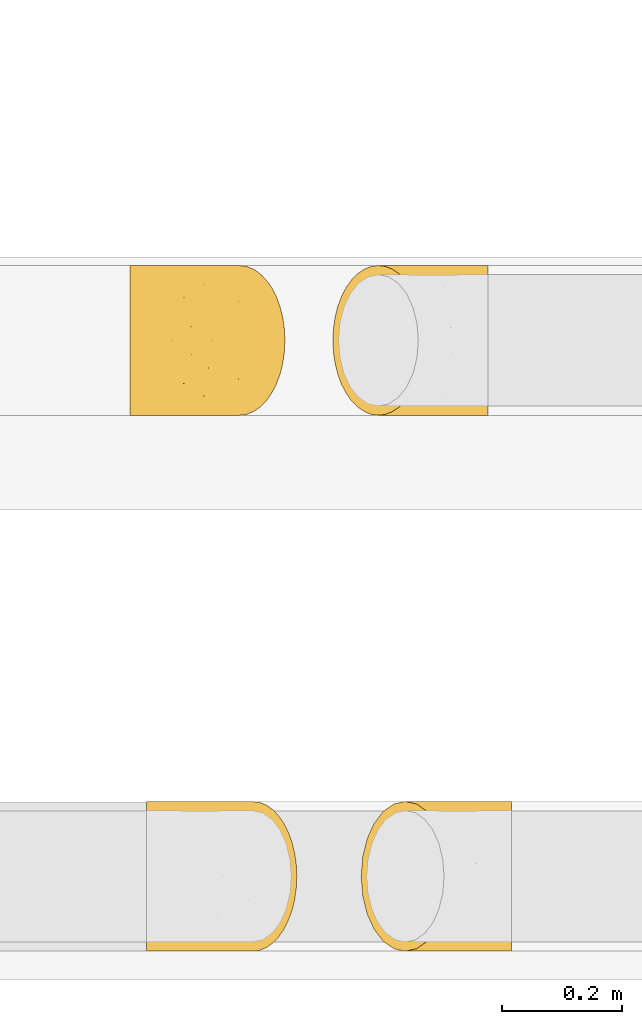
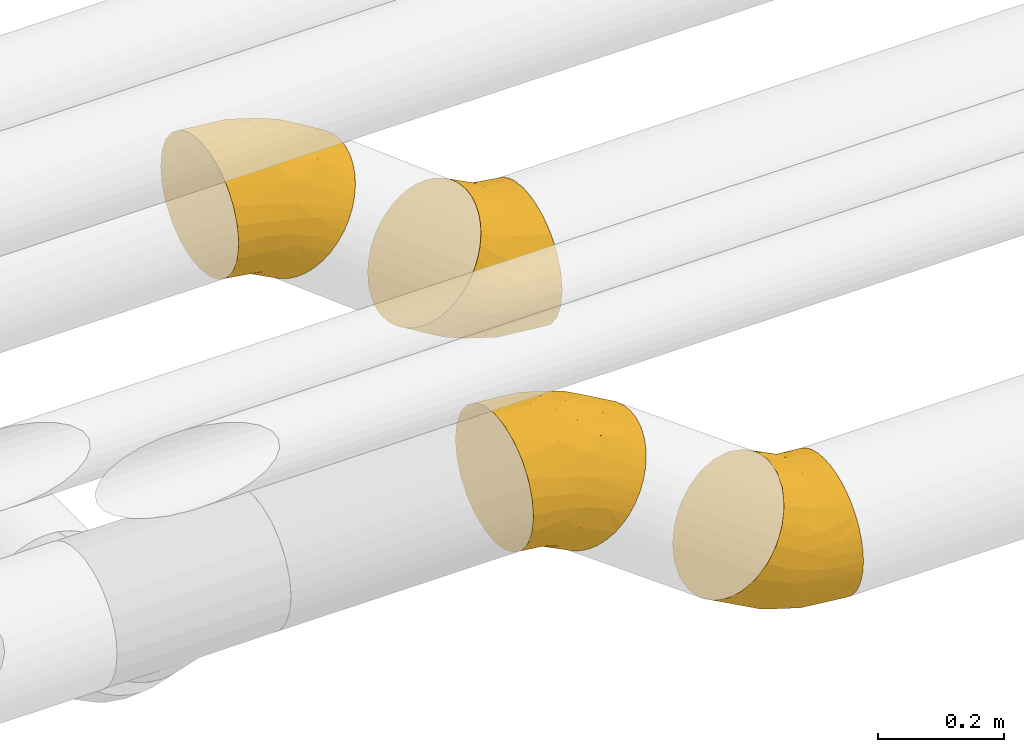
# One storey, part 140 of 827: 4 coverings.
"""IFC2X3 building model written with IfcOpenShell, lengths in millimetres."""

from ifc_helpers import new_model, entity, si_unit, converted_unit, derived_unit, direction, frame, origin, place, context, subcontext, project, spatial, faceted_brep, element, save


model = new_model("IFC2X3")

# Units and contexts
model_context = context("Model", 3, precision=0.01, world=origin(), true_north=direction((6.12303176911189e-17, 1.0)))
body_context = subcontext(model_context, "Body", "Model", "MODEL_VIEW")
ifc_project = project(units=[si_unit("LENGTHUNIT", "METRE", prefix="MILLI"), si_unit("AREAUNIT", "SQUARE_METRE"), si_unit("VOLUMEUNIT", "CUBIC_METRE"), converted_unit("PLANEANGLEUNIT", "DEGREE", entity("IfcRatioMeasure", 0.0174532925199433), si_unit("PLANEANGLEUNIT", "RADIAN"), dimensions=[0, 0, 0, 0, 0, 0, 0]), si_unit("MASSUNIT", "GRAM", prefix="KILO"), derived_unit("MASSDENSITYUNIT", [(si_unit("MASSUNIT", "GRAM", prefix="KILO"), 1), (si_unit("LENGTHUNIT", "METRE"), -3)]), derived_unit("MOMENTOFINERTIAUNIT", [(si_unit("LENGTHUNIT", "METRE"), 4)]), si_unit("TIMEUNIT", "SECOND"), si_unit("FREQUENCYUNIT", "HERTZ"), si_unit("THERMODYNAMICTEMPERATUREUNIT", "DEGREE_CELSIUS"), derived_unit("THERMALTRANSMITTANCEUNIT", [(si_unit("MASSUNIT", "GRAM", prefix="KILO"), 1), (si_unit("THERMODYNAMICTEMPERATUREUNIT", "KELVIN"), -1), (si_unit("TIMEUNIT", "SECOND"), -3)]), derived_unit("VOLUMETRICFLOWRATEUNIT", [(si_unit("LENGTHUNIT", "METRE"), 3), (si_unit("TIMEUNIT", "SECOND"), -1)]), derived_unit("MASSFLOWRATEUNIT", [(si_unit("MASSUNIT", "GRAM", prefix="KILO"), 1), (si_unit("TIMEUNIT", "SECOND"), -1)]), derived_unit("ROTATIONALFREQUENCYUNIT", [(si_unit("TIMEUNIT", "SECOND"), -1)]), si_unit("ELECTRICCURRENTUNIT", "AMPERE"), si_unit("ELECTRICVOLTAGEUNIT", "VOLT"), si_unit("POWERUNIT", "WATT"), si_unit("FORCEUNIT", "NEWTON", prefix="KILO"), si_unit("ILLUMINANCEUNIT", "LUX"), si_unit("LUMINOUSFLUXUNIT", "LUMEN"), si_unit("LUMINOUSINTENSITYUNIT", "CANDELA"), derived_unit("USERDEFINED", [(si_unit("MASSUNIT", "GRAM", prefix="KILO"), -1), (si_unit("LENGTHUNIT", "METRE"), -2), (si_unit("TIMEUNIT", "SECOND"), 3), (si_unit("LUMINOUSFLUXUNIT", "LUMEN"), 1)]), derived_unit("LINEARVELOCITYUNIT", [(si_unit("LENGTHUNIT", "METRE"), 1), (si_unit("TIMEUNIT", "SECOND"), -1)]), si_unit("PRESSUREUNIT", "PASCAL"), derived_unit("USERDEFINED", [(si_unit("LENGTHUNIT", "METRE"), -2), (si_unit("MASSUNIT", "GRAM", prefix="KILO"), 1), (si_unit("TIMEUNIT", "SECOND"), -2)]), derived_unit("LINEARFORCEUNIT", [(si_unit("MASSUNIT", "GRAM", prefix="KILO"), 1), (si_unit("LENGTHUNIT", "METRE"), 1), (si_unit("TIMEUNIT", "SECOND"), -2), (si_unit("LENGTHUNIT", "METRE"), -1)]), derived_unit("PLANARFORCEUNIT", [(si_unit("MASSUNIT", "GRAM", prefix="KILO"), 1), (si_unit("LENGTHUNIT", "METRE"), 1), (si_unit("TIMEUNIT", "SECOND"), -2), (si_unit("LENGTHUNIT", "METRE"), -2)])], contexts=[model_context])

# Site, building, storey
site_placement = place(None, origin())
site = spatial("IfcSite", under=ifc_project, at=site_placement, CompositionType="ELEMENT")
building_placement = place(site_placement, origin())
building = spatial("IfcBuilding", under=site, at=building_placement, CompositionType="ELEMENT")
storey_placement = place(building_placement, frame((0.0, 0.0, 28200.0)))
storey = spatial("IfcBuildingStorey", under=building, at=storey_placement, Name="08", CompositionType="ELEMENT", Elevation=28200.0)

# Coverings
covering_1_placement = place(storey_placement, frame((32034.49, 6248.9, 2640.23)))
element("IfcCovering", 1, at=covering_1_placement, inside=storey, Name=":ADSK_", ObjectType=":ADSK_", PredefinedType="INSULATION", context=body_context, shape_type="Brep", body=[
    faceted_brep([(108.56, 164.57, 6.52), (112.96, 182.62, 12.56), (118.98, 199.28, 20.81), (126.45, 214.13, 31.07), (135.2, 226.82, 43.07), (145.01, 237.03, 56.53), (155.64, 244.5, 71.12), (166.83, 249.06, 86.47), (178.3, 250.6, 102.21), (189.77, 249.06, 117.95), (200.96, 244.5, 133.3), (211.6, 237.02, 147.88), (221.41, 226.82, 161.35), (230.16, 214.13, 173.35), (237.63, 199.27, 183.6), (243.64, 182.61, 191.85), (248.05, 164.56, 197.89), (250.73, 145.56, 201.58), (251.63, 126.1, 202.82), (250.73, 106.62, 201.58), (248.05, 87.62, 197.89), (243.64, 69.57, 191.85), (237.63, 52.91, 183.6), (230.15, 38.06, 173.35), (221.4, 25.37, 161.34), (211.59, 15.16, 147.88), (200.96, 7.69, 133.29), (189.77, 3.13, 117.94), (178.3, 1.6, 102.21), (166.83, 3.13, 86.47), (155.64, 7.69, 71.11), (145.01, 15.17, 56.53), (135.2, 25.37, 43.07), (126.45, 38.06, 31.06), (118.97, 52.92, 20.81), (112.96, 69.58, 12.56), (108.56, 87.63, 6.52), (105.87, 106.63, 2.83), (104.97, 126.1, 1.6), (105.87, 145.57, 2.83), (1.6, 38.06, 71.74), (1.6, 18.28, 97.52), (1.6, 5.84, 127.55), (1.6, 1.6, 159.77), (1.6, 5.84, 191.99), (1.6, 18.28, 222.02), (1.6, 38.06, 247.81), (1.6, 63.85, 267.59), (1.6, 93.87, 280.03), (1.6, 126.1, 284.27), (1.6, 158.32, 280.03), (1.6, 188.35, 267.59), (1.6, 214.13, 247.81), (1.6, 233.92, 222.02), (1.6, 246.35, 191.99), (1.6, 250.6, 159.77), (1.6, 246.35, 127.55), (1.6, 233.92, 97.52), (1.6, 214.13, 71.74), (1.6, 188.35, 51.95), (1.6, 158.32, 39.51), (1.6, 126.1, 35.27), (1.6, 93.87, 39.51), (1.6, 63.85, 51.95), (68.16, 126.1, 279.02), (100.1, 149.38, 270.42), (79.98, 247.9, 175.97), (106.87, 239.8, 194.3), (48.64, 250.6, 156.06), (127.4, 172.24, 255.9), (89.79, 197.68, 251.83), (133.08, 126.1, 263.39), (120.19, 219.0, 223.82), (183.7, 154.51, 239.59), (94.52, 250.6, 145.02), (138.1, 250.6, 126.92), (169.3, 192.26, 228.93), (194.75, 126.1, 237.78), (41.07, 238.65, 103.38), (37.64, 226.55, 83.33), (61.96, 246.7, 122.03), (110.4, 248.86, 116.97), (114.9, 242.64, 89.58), (76.9, 235.39, 88.05), (56.7, 150.5, 28.94), (38.17, 126.1, 31.42), (66.04, 210.04, 57.6), (57.22, 176.02, 37.21), (73.14, 126.1, 20.03), (57.21, 76.18, 37.2), (56.7, 101.7, 28.93), (70.71, 28.16, 71.93), (45.54, 48.23, 57.81), (92.82, 8.73, 101.6), (65.07, 3.38, 131.44), (43.54, 9.61, 112.37), (41.42, 20.18, 90.92), (48.64, 1.6, 156.06), (87.67, 43.38, 47.97), (94.52, 1.6, 145.02), (138.1, 1.6, 126.92), (79.98, 4.29, 175.96), (120.19, 33.19, 223.82), (155.02, 54.8, 231.41), (75.44, 48.97, 250.59), (106.86, 12.38, 194.29), (100.1, 102.8, 270.42), (127.4, 79.94, 255.9), (183.69, 97.67, 239.59)], [[[0, 1, 2, 3, 4, 5, 6, 7, 8, 9, 10, 11, 12, 13, 14, 15, 16, 17, 18, 19, 20, 21, 22, 23, 24, 25, 26, 27, 28, 29, 30, 31, 32, 33, 34, 35, 36, 37, 38, 39]], [[40, 41, 42, 43, 44, 45, 46, 47, 48, 49, 50, 51, 52, 53, 54, 55, 56, 57, 58, 59, 60, 61, 62, 63]], [[50, 64, 65]], [[64, 50, 49]], [[66, 67, 10]], [[66, 68, 55]], [[69, 70, 51]], [[65, 64, 71]], [[52, 51, 70]], [[53, 52, 72]], [[72, 67, 53]], [[73, 69, 65]], [[66, 55, 54]], [[74, 68, 66]], [[50, 65, 69]], [[73, 65, 71]], [[12, 11, 67]], [[54, 67, 66]], [[75, 74, 66]], [[9, 66, 10]], [[54, 53, 67]], [[76, 15, 14]], [[71, 77, 73]], [[77, 17, 73]], [[13, 72, 76]], [[76, 73, 15]], [[72, 70, 76]], [[15, 73, 16]], [[17, 77, 18]], [[51, 50, 69]], [[66, 9, 75]], [[8, 75, 9]], [[76, 69, 73]], [[52, 70, 72]], [[72, 12, 67]], [[10, 67, 11]], [[13, 12, 72]], [[76, 14, 13]], [[16, 73, 17]], [[76, 70, 69]], [[78, 79, 57]], [[56, 55, 68]], [[80, 68, 74]], [[81, 80, 74]], [[80, 81, 82]], [[57, 79, 58]], [[80, 83, 78]], [[60, 84, 85]], [[82, 83, 80]], [[59, 86, 87]], [[84, 88, 85]], [[0, 39, 84]], [[86, 79, 83]], [[85, 61, 60]], [[60, 87, 84]], [[84, 87, 0]], [[59, 58, 86]], [[78, 83, 79]], [[81, 74, 75]], [[4, 83, 82]], [[4, 82, 5]], [[81, 7, 6]], [[83, 4, 86]], [[7, 81, 75]], [[82, 81, 6]], [[8, 7, 75]], [[56, 68, 80]], [[56, 78, 57]], [[4, 3, 86]], [[38, 88, 39]], [[84, 39, 88]], [[56, 80, 78]], [[86, 58, 79]], [[2, 87, 86]], [[2, 86, 3]], [[2, 1, 87]], [[1, 0, 87]], [[60, 59, 87]], [[6, 5, 82]], [[35, 89, 36]], [[62, 85, 90]], [[88, 90, 85]], [[85, 62, 61]], [[62, 90, 89]], [[91, 40, 92]], [[93, 94, 95]], [[40, 96, 41]], [[95, 96, 93]], [[43, 42, 97]], [[95, 94, 42]], [[63, 92, 40]], [[89, 98, 92]], [[95, 42, 41]], [[96, 95, 41]], [[93, 99, 94]], [[37, 36, 90]], [[93, 32, 31]], [[40, 91, 96]], [[35, 34, 98]], [[90, 36, 89]], [[100, 93, 30]], [[99, 97, 94]], [[98, 32, 91]], [[33, 32, 98]], [[63, 62, 89]], [[98, 91, 92]], [[91, 32, 93]], [[93, 31, 30]], [[37, 90, 88]], [[93, 100, 99]], [[89, 35, 98]], [[42, 94, 97]], [[29, 28, 100]], [[30, 29, 100]], [[33, 98, 34]], [[63, 89, 92]], [[37, 88, 38]], [[93, 96, 91]], [[101, 44, 43]], [[101, 43, 97]], [[102, 103, 104]], [[45, 102, 46]], [[101, 27, 26]], [[99, 101, 97]], [[44, 105, 45]], [[102, 45, 105]], [[64, 49, 48]], [[64, 106, 71]], [[48, 107, 106]], [[46, 102, 104]], [[23, 22, 103]], [[20, 108, 21]], [[105, 25, 24]], [[100, 27, 101]], [[26, 105, 101]], [[47, 46, 104]], [[105, 26, 25]], [[24, 23, 102]], [[104, 107, 47]], [[21, 103, 22]], [[105, 24, 102]], [[107, 104, 103]], [[102, 23, 103]], [[19, 108, 20]], [[21, 107, 103]], [[48, 106, 64]], [[71, 106, 108]], [[19, 18, 77]], [[19, 77, 108]], [[44, 101, 105]], [[21, 108, 107]], [[71, 108, 77]], [[48, 47, 107]], [[108, 106, 107]], [[27, 100, 28]], [[101, 99, 100]]]),
])
covering_2_placement = place(storey_placement, frame((32391.5, 6248.9, 2373.9)))
element("IfcCovering", 2, at=covering_2_placement, inside=storey, Name=":ADSK_", ObjectType=":ADSK_", PredefinedType="INSULATION", context=body_context, shape_type="Brep", body=[
    faceted_brep([(251.63, 15.16, 182.61), (251.63, 7.69, 164.56), (251.63, 3.13, 145.56), (251.63, 1.6, 126.1), (251.63, 3.13, 106.62), (251.63, 7.69, 87.62), (251.63, 15.17, 69.57), (251.63, 25.37, 52.91), (251.63, 38.06, 38.06), (251.63, 52.92, 25.37), (251.63, 69.58, 15.16), (251.63, 87.63, 7.69), (251.63, 106.63, 3.13), (251.63, 126.1, 1.6), (251.63, 145.57, 3.13), (251.63, 164.57, 7.69), (251.63, 182.62, 15.17), (251.63, 199.28, 25.37), (251.63, 214.13, 38.06), (251.63, 226.82, 52.92), (251.63, 237.03, 69.58), (251.63, 244.5, 87.63), (251.63, 249.06, 106.63), (251.63, 250.6, 126.1), (251.63, 249.06, 145.57), (251.63, 244.5, 164.57), (251.63, 237.02, 182.62), (251.63, 226.82, 199.28), (251.63, 214.13, 214.13), (251.63, 199.27, 226.82), (251.63, 182.61, 237.03), (251.63, 164.56, 244.5), (251.63, 145.56, 249.06), (251.63, 126.1, 250.6), (251.63, 106.62, 249.06), (251.63, 87.62, 244.5), (251.63, 69.57, 237.02), (251.63, 52.91, 226.82), (251.63, 38.06, 214.13), (251.63, 25.37, 199.27), (126.78, 214.13, 254.8), (111.59, 233.92, 233.97), (93.91, 246.35, 209.7), (74.93, 250.6, 183.66), (55.95, 246.35, 157.62), (38.26, 233.92, 133.35), (23.07, 214.13, 112.52), (11.42, 188.35, 96.53), (4.09, 158.32, 86.48), (1.6, 126.1, 83.05), (4.09, 93.87, 86.48), (11.42, 63.85, 96.53), (23.07, 38.06, 112.52), (38.26, 18.28, 133.35), (55.95, 5.84, 157.62), (74.93, 1.6, 183.66), (93.91, 5.84, 209.7), (111.59, 18.28, 233.97), (126.78, 38.06, 254.8), (138.44, 63.85, 270.79), (145.76, 93.87, 280.84), (148.26, 126.1, 284.27), (145.76, 158.32, 280.84), (138.44, 188.35, 270.79), (58.48, 126.1, 48.08), (89.36, 102.81, 36.22), (128.73, 4.29, 124.4), (139.66, 12.39, 93.75), (115.13, 1.6, 158.95), (119.97, 79.95, 31.87), (91.98, 54.51, 57.31), (120.15, 126.1, 22.47), (133.04, 33.19, 62.04), (175.08, 97.68, 11.9), (158.71, 1.6, 140.85), (204.59, 1.6, 129.81), (169.72, 59.93, 28.99), (185.07, 126.1, 6.85), (140.05, 13.54, 205.98), (149.08, 25.64, 224.2), (145.94, 5.49, 178.6), (188.07, 3.33, 154.16), (207.84, 9.55, 173.65), (178.03, 16.8, 197.26), (196.53, 101.69, 256.93), (180.09, 126.1, 265.84), (187.19, 42.15, 228.27), (192.07, 76.17, 249.94), (215.06, 126.1, 254.45), (192.07, 176.01, 249.95), (196.53, 150.49, 256.93), (182.52, 224.03, 213.94), (170.5, 203.96, 240.17), (182.91, 243.46, 176.93), (142.91, 248.81, 169.16), (136.74, 242.58, 197.26), (147.66, 232.01, 215.84), (115.13, 250.6, 158.95), (210.34, 208.81, 223.31), (158.71, 250.6, 140.85), (204.59, 250.6, 129.81), (128.73, 247.9, 124.41), (133.04, 219.0, 62.05), (156.72, 197.39, 35.39), (81.11, 203.22, 66.77), (139.66, 239.81, 93.76), (89.36, 149.39, 36.22), (119.97, 172.25, 31.87), (175.07, 154.52, 11.9)], [[[0, 1, 2, 3, 4, 5, 6, 7, 8, 9, 10, 11, 12, 13, 14, 15, 16, 17, 18, 19, 20, 21, 22, 23, 24, 25, 26, 27, 28, 29, 30, 31, 32, 33, 34, 35, 36, 37, 38, 39]], [[40, 41, 42, 43, 44, 45, 46, 47, 48, 49, 50, 51, 52, 53, 54, 55, 56, 57, 58, 59, 60, 61, 62, 63]], [[50, 64, 65]], [[64, 50, 49]], [[66, 67, 5]], [[66, 68, 55]], [[69, 70, 51]], [[65, 64, 71]], [[52, 51, 70]], [[53, 52, 72]], [[72, 67, 53]], [[73, 69, 65]], [[66, 55, 54]], [[74, 68, 66]], [[50, 65, 69]], [[73, 65, 71]], [[7, 6, 67]], [[54, 67, 66]], [[75, 74, 66]], [[4, 66, 5]], [[54, 53, 67]], [[76, 10, 9]], [[71, 77, 73]], [[77, 12, 73]], [[8, 72, 76]], [[76, 73, 10]], [[72, 70, 76]], [[10, 73, 11]], [[12, 77, 13]], [[51, 50, 69]], [[66, 4, 75]], [[3, 75, 4]], [[76, 69, 73]], [[52, 70, 72]], [[72, 7, 67]], [[5, 67, 6]], [[8, 7, 72]], [[76, 9, 8]], [[11, 73, 12]], [[76, 70, 69]], [[78, 79, 57]], [[56, 55, 68]], [[80, 68, 74]], [[81, 80, 74]], [[80, 81, 82]], [[57, 79, 58]], [[80, 83, 78]], [[60, 84, 85]], [[82, 83, 80]], [[59, 86, 87]], [[84, 88, 85]], [[35, 34, 84]], [[86, 79, 83]], [[85, 61, 60]], [[60, 87, 84]], [[84, 87, 35]], [[59, 58, 86]], [[78, 83, 79]], [[81, 74, 75]], [[39, 83, 82]], [[39, 82, 0]], [[81, 2, 1]], [[83, 39, 86]], [[2, 81, 75]], [[82, 81, 1]], [[3, 2, 75]], [[56, 68, 80]], [[56, 78, 57]], [[39, 38, 86]], [[33, 88, 34]], [[84, 34, 88]], [[56, 80, 78]], [[86, 58, 79]], [[37, 87, 86]], [[37, 86, 38]], [[37, 36, 87]], [[36, 35, 87]], [[60, 59, 87]], [[1, 0, 82]], [[30, 89, 31]], [[62, 85, 90]], [[88, 90, 85]], [[85, 62, 61]], [[62, 90, 89]], [[91, 40, 92]], [[93, 94, 95]], [[40, 96, 41]], [[95, 96, 93]], [[43, 42, 97]], [[95, 94, 42]], [[63, 92, 40]], [[89, 98, 92]], [[95, 42, 41]], [[96, 95, 41]], [[93, 99, 94]], [[32, 31, 90]], [[93, 27, 26]], [[40, 91, 96]], [[30, 29, 98]], [[90, 31, 89]], [[100, 93, 25]], [[99, 97, 94]], [[98, 27, 91]], [[28, 27, 98]], [[63, 62, 89]], [[98, 91, 92]], [[91, 27, 93]], [[93, 26, 25]], [[32, 90, 88]], [[93, 100, 99]], [[89, 30, 98]], [[42, 94, 97]], [[24, 23, 100]], [[25, 24, 100]], [[28, 98, 29]], [[63, 89, 92]], [[32, 88, 33]], [[93, 96, 91]], [[101, 44, 43]], [[101, 43, 97]], [[102, 103, 104]], [[45, 102, 46]], [[101, 22, 21]], [[99, 101, 97]], [[44, 105, 45]], [[102, 45, 105]], [[64, 49, 48]], [[64, 106, 71]], [[48, 107, 106]], [[46, 102, 104]], [[18, 17, 103]], [[15, 108, 16]], [[105, 20, 19]], [[100, 22, 101]], [[21, 105, 101]], [[47, 46, 104]], [[105, 21, 20]], [[19, 18, 102]], [[104, 107, 47]], [[16, 103, 17]], [[105, 19, 102]], [[107, 104, 103]], [[102, 18, 103]], [[14, 108, 15]], [[16, 107, 103]], [[48, 106, 64]], [[71, 106, 108]], [[14, 13, 77]], [[14, 77, 108]], [[44, 101, 105]], [[16, 108, 107]], [[71, 108, 77]], [[48, 47, 107]], [[108, 106, 107]], [[22, 100, 23]], [[101, 99, 100]]]),
])
covering_3_placement = place(storey_placement, frame((32344.41, 7140.11, 2373.87)))
element("IfcCovering", 3, at=covering_3_placement, inside=storey, Name=":ADSK_", ObjectType=":ADSK_", PredefinedType="INSULATION", context=body_context, shape_type="Brep", body=[
    faceted_brep([(144.61, 182.62, 275.91), (138.41, 199.28, 267.8), (130.7, 214.13, 257.72), (121.68, 226.82, 245.92), (111.56, 237.03, 232.69), (100.59, 244.5, 218.35), (89.05, 249.06, 203.26), (77.23, 250.6, 187.8), (65.39, 249.06, 172.32), (53.85, 244.5, 157.23), (42.89, 237.02, 142.9), (32.77, 226.82, 129.66), (23.75, 214.13, 117.86), (16.04, 199.27, 107.79), (9.84, 182.61, 99.68), (5.3, 164.56, 93.74), (2.53, 145.56, 90.12), (1.6, 126.1, 88.9), (2.53, 106.62, 90.12), (5.3, 87.62, 93.74), (9.84, 69.57, 99.68), (16.04, 52.91, 107.79), (23.75, 38.06, 117.87), (32.77, 25.37, 129.67), (42.89, 15.16, 142.9), (53.86, 7.69, 157.24), (65.4, 3.13, 172.33), (77.23, 1.6, 187.8), (89.06, 3.13, 203.27), (100.6, 7.69, 218.36), (111.56, 15.17, 232.69), (121.68, 25.37, 245.93), (130.71, 38.06, 257.73), (138.42, 52.92, 267.81), (144.62, 69.58, 275.91), (149.16, 87.63, 281.85), (151.93, 106.63, 285.47), (152.86, 126.1, 286.69), (151.93, 145.57, 285.47), (149.16, 164.57, 281.85), (259.47, 38.06, 214.13), (259.47, 18.28, 188.35), (259.47, 5.84, 158.32), (259.47, 1.6, 126.1), (259.47, 5.84, 93.87), (259.47, 18.28, 63.85), (259.47, 38.06, 38.06), (259.47, 63.85, 18.28), (259.47, 93.87, 5.84), (259.47, 126.1, 1.6), (259.47, 158.32, 5.84), (259.47, 188.35, 18.28), (259.47, 214.13, 38.06), (259.47, 233.92, 63.85), (259.47, 246.35, 93.87), (259.47, 250.6, 126.1), (259.47, 246.35, 158.32), (259.47, 233.92, 188.35), (259.47, 214.13, 214.13), (259.47, 188.35, 233.92), (259.47, 158.32, 246.35), (259.47, 126.1, 250.6), (259.47, 93.87, 246.35), (259.47, 63.85, 233.92), (190.49, 126.1, 7.24), (157.43, 149.32, 16.3), (112.52, 246.63, 129.33), (148.09, 239.73, 93.39), (178.22, 247.86, 110.44), (210.72, 250.6, 130.08), (79.34, 190.06, 61.34), (169.08, 197.56, 34.44), (128.99, 172.14, 31.43), (123.34, 126.1, 24.01), (136.64, 218.87, 63.29), (70.42, 154.47, 49.68), (163.27, 250.6, 141.94), (59.82, 126.1, 51.48), (118.37, 250.6, 161.35), (218.83, 239.09, 181.71), (221.95, 226.68, 202.6), (196.86, 246.76, 164.12), (146.84, 248.89, 170.32), (141.89, 242.74, 198.16), (181.44, 235.62, 198.3), (192.68, 210.27, 228.83), (201.72, 176.19, 249.27), (202.42, 150.5, 257.57), (185.47, 126.1, 266.96), (221.58, 126.1, 254.73), (201.73, 76.01, 249.27), (202.42, 101.69, 257.58), (163.27, 1.6, 141.94), (146.85, 3.3, 170.32), (118.37, 1.6, 161.35), (192.69, 41.93, 228.83), (141.9, 9.46, 198.17), (181.44, 16.58, 198.31), (218.84, 13.1, 181.71), (221.96, 25.52, 202.6), (210.72, 1.6, 130.08), (196.87, 5.43, 164.13), (148.1, 12.45, 93.39), (112.52, 5.55, 129.34), (178.22, 4.33, 110.44), (136.65, 33.32, 63.3), (169.09, 54.62, 34.45), (157.43, 102.86, 16.3), (128.99, 80.05, 31.43), (79.35, 62.12, 61.34), (70.42, 97.72, 49.68)], [[[0, 1, 2, 3, 4, 5, 6, 7, 8, 9, 10, 11, 12, 13, 14, 15, 16, 17, 18, 19, 20, 21, 22, 23, 24, 25, 26, 27, 28, 29, 30, 31, 32, 33, 34, 35, 36, 37, 38, 39]], [[40, 41, 42, 43, 44, 45, 46, 47, 48, 49, 50, 51, 52, 53, 54, 55, 56, 57, 58, 59, 60, 61, 62, 63]], [[50, 64, 65]], [[64, 50, 49]], [[10, 66, 67]], [[68, 69, 55]], [[70, 71, 72]], [[65, 64, 73]], [[52, 51, 71]], [[53, 52, 74]], [[53, 67, 54]], [[75, 72, 65]], [[68, 55, 54]], [[76, 69, 68]], [[71, 70, 74]], [[12, 70, 13]], [[11, 10, 67]], [[54, 67, 68]], [[76, 68, 66]], [[9, 8, 66]], [[53, 74, 67]], [[70, 14, 13]], [[73, 77, 75]], [[77, 16, 75]], [[12, 74, 70]], [[70, 75, 14]], [[70, 72, 75]], [[14, 75, 15]], [[16, 77, 17]], [[51, 50, 72]], [[78, 76, 66]], [[7, 78, 8]], [[78, 66, 8]], [[50, 65, 72]], [[10, 9, 66]], [[67, 74, 11]], [[51, 72, 71]], [[52, 71, 74]], [[12, 11, 74]], [[67, 66, 68]], [[15, 75, 16]], [[75, 65, 73]], [[79, 80, 57]], [[56, 55, 69]], [[81, 69, 76]], [[82, 81, 76]], [[81, 82, 83]], [[57, 80, 58]], [[84, 79, 81]], [[84, 80, 79]], [[83, 84, 81]], [[59, 85, 86]], [[87, 88, 89]], [[39, 38, 87]], [[85, 80, 84]], [[89, 61, 60]], [[60, 86, 87]], [[56, 69, 81]], [[59, 58, 85]], [[60, 87, 89]], [[84, 83, 3]], [[3, 2, 85]], [[3, 83, 4]], [[82, 6, 5]], [[84, 3, 85]], [[6, 82, 78]], [[83, 82, 5]], [[7, 6, 78]], [[87, 86, 39]], [[56, 79, 57]], [[79, 56, 81]], [[37, 88, 38]], [[87, 38, 88]], [[76, 78, 82]], [[85, 58, 80]], [[1, 86, 85]], [[1, 85, 2]], [[1, 0, 86]], [[0, 39, 86]], [[60, 59, 86]], [[5, 4, 83]], [[34, 90, 35]], [[62, 89, 91]], [[88, 91, 89]], [[89, 62, 61]], [[92, 93, 94]], [[95, 63, 90]], [[93, 96, 29]], [[97, 98, 99]], [[98, 41, 99]], [[43, 42, 100]], [[97, 96, 101]], [[95, 97, 99]], [[95, 99, 40]], [[41, 40, 99]], [[100, 42, 101]], [[98, 42, 41]], [[36, 35, 91]], [[96, 30, 29]], [[92, 100, 101]], [[34, 33, 90]], [[91, 35, 90]], [[95, 32, 31]], [[63, 95, 40]], [[95, 31, 97]], [[32, 95, 33]], [[63, 62, 90]], [[90, 33, 95]], [[31, 96, 97]], [[30, 96, 31]], [[93, 29, 28]], [[101, 96, 93]], [[62, 91, 90]], [[101, 93, 92]], [[28, 27, 94]], [[94, 93, 28]], [[98, 97, 101]], [[36, 91, 88]], [[36, 88, 37]], [[42, 98, 101]], [[102, 103, 24]], [[104, 43, 100]], [[46, 105, 106]], [[45, 105, 46]], [[103, 26, 25]], [[92, 104, 100]], [[43, 104, 44]], [[44, 102, 45]], [[64, 49, 48]], [[64, 107, 73]], [[48, 108, 107]], [[109, 106, 105]], [[22, 21, 109]], [[19, 110, 20]], [[45, 102, 105]], [[26, 103, 94]], [[102, 104, 103]], [[108, 47, 106]], [[103, 104, 92]], [[23, 102, 24]], [[23, 22, 105]], [[110, 107, 108]], [[48, 107, 64]], [[102, 23, 105]], [[103, 25, 24]], [[109, 21, 20]], [[18, 110, 19]], [[110, 109, 20]], [[106, 109, 108]], [[73, 107, 110]], [[18, 17, 77]], [[18, 77, 110]], [[44, 104, 102]], [[110, 108, 109]], [[73, 110, 77]], [[48, 47, 108]], [[22, 109, 105]], [[26, 94, 27]], [[46, 106, 47]], [[92, 94, 103]]]),
])
covering_4_placement = place(storey_placement, frame((32006.84, 7140.11, 2637.8)))
element("IfcCovering", 4, at=covering_4_placement, inside=storey, Name=":ADSK_", ObjectType=":ADSK_", PredefinedType="INSULATION", context=body_context, shape_type="Brep", body=[
    faceted_brep([(111.91, 164.57, 6.44), (116.45, 182.62, 12.38), (122.65, 199.28, 20.48), (130.36, 214.13, 30.56), (139.39, 226.82, 42.36), (149.51, 237.03, 55.6), (160.47, 244.5, 69.94), (172.01, 249.06, 85.03), (183.84, 250.6, 100.49), (195.67, 249.06, 115.96), (207.21, 244.5, 131.05), (218.18, 237.02, 145.39), (228.3, 226.82, 158.62), (237.32, 214.13, 170.42), (245.03, 199.27, 180.5), (251.23, 182.61, 188.61), (255.77, 164.56, 194.55), (258.54, 145.56, 198.17), (259.47, 126.1, 199.38), (258.54, 106.62, 198.17), (255.77, 87.62, 194.54), (251.23, 69.57, 188.6), (245.03, 52.91, 180.49), (237.32, 38.06, 170.42), (228.29, 25.37, 158.61), (218.17, 15.16, 145.38), (207.21, 7.69, 131.04), (195.67, 3.13, 115.95), (183.84, 1.6, 100.49), (172.01, 3.13, 85.02), (160.47, 7.69, 69.93), (149.5, 15.17, 55.59), (139.38, 25.37, 42.36), (130.36, 38.06, 30.56), (122.65, 52.92, 20.48), (116.45, 69.58, 12.37), (111.91, 87.63, 6.43), (109.14, 106.63, 2.81), (108.21, 126.1, 1.6), (109.14, 145.57, 2.81), (1.6, 38.06, 74.16), (1.6, 18.28, 99.94), (1.6, 5.84, 129.97), (1.6, 1.6, 162.19), (1.6, 5.84, 194.41), (1.6, 18.28, 224.44), (1.6, 38.06, 250.22), (1.6, 63.85, 270.01), (1.6, 93.87, 282.45), (1.6, 126.1, 286.69), (1.6, 158.32, 282.45), (1.6, 188.35, 270.01), (1.6, 214.13, 250.22), (1.6, 233.92, 224.44), (1.6, 246.35, 194.41), (1.6, 250.6, 162.19), (1.6, 246.35, 129.97), (1.6, 233.92, 99.94), (1.6, 214.13, 74.16), (1.6, 188.35, 54.37), (1.6, 158.32, 41.93), (1.6, 126.1, 37.69), (1.6, 93.87, 41.93), (1.6, 63.85, 54.37), (70.58, 126.1, 281.05), (103.64, 149.32, 271.99), (148.55, 246.63, 158.95), (112.98, 239.73, 194.9), (82.85, 247.86, 177.85), (50.34, 250.6, 158.2), (181.72, 190.06, 226.95), (91.98, 197.56, 253.84), (132.08, 172.14, 256.85), (137.72, 126.1, 264.27), (124.43, 218.87, 224.99), (190.65, 154.47, 238.61), (97.8, 250.6, 146.35), (201.25, 126.1, 236.81), (142.69, 250.6, 126.94), (42.23, 239.09, 106.57), (39.11, 226.68, 85.69), (64.2, 246.76, 124.16), (114.22, 248.89, 117.97), (119.17, 242.74, 90.12), (79.63, 235.62, 89.99), (68.38, 210.27, 59.46), (59.34, 176.19, 39.02), (58.65, 150.5, 30.71), (75.59, 126.1, 21.33), (39.49, 126.1, 33.55), (59.34, 76.01, 39.02), (58.65, 101.69, 30.71), (97.8, 1.6, 146.35), (114.22, 3.3, 117.97), (142.69, 1.6, 126.94), (68.38, 41.93, 59.45), (119.17, 9.46, 90.12), (79.63, 16.58, 89.98), (42.23, 13.1, 106.57), (39.11, 25.52, 85.69), (50.34, 1.6, 158.2), (64.2, 5.43, 124.16), (112.97, 12.45, 194.89), (148.55, 5.55, 158.94), (82.84, 4.33, 177.84), (124.42, 33.32, 224.99), (91.98, 54.62, 253.84), (103.64, 102.86, 271.99), (132.07, 80.05, 256.85), (181.72, 62.12, 226.94), (190.64, 97.72, 238.61)], [[[0, 1, 2, 3, 4, 5, 6, 7, 8, 9, 10, 11, 12, 13, 14, 15, 16, 17, 18, 19, 20, 21, 22, 23, 24, 25, 26, 27, 28, 29, 30, 31, 32, 33, 34, 35, 36, 37, 38, 39]], [[40, 41, 42, 43, 44, 45, 46, 47, 48, 49, 50, 51, 52, 53, 54, 55, 56, 57, 58, 59, 60, 61, 62, 63]], [[50, 64, 65]], [[64, 50, 49]], [[11, 66, 67]], [[68, 69, 55]], [[70, 71, 72]], [[65, 64, 73]], [[52, 51, 71]], [[53, 52, 74]], [[53, 67, 54]], [[75, 72, 65]], [[68, 55, 54]], [[76, 69, 68]], [[71, 70, 74]], [[13, 70, 14]], [[12, 11, 67]], [[54, 67, 68]], [[76, 68, 66]], [[10, 9, 66]], [[53, 74, 67]], [[70, 15, 14]], [[73, 77, 75]], [[77, 17, 75]], [[13, 74, 70]], [[70, 75, 15]], [[70, 72, 75]], [[15, 75, 16]], [[17, 77, 18]], [[51, 50, 72]], [[78, 76, 66]], [[8, 78, 9]], [[78, 66, 9]], [[50, 65, 72]], [[11, 10, 66]], [[67, 74, 12]], [[51, 72, 71]], [[52, 71, 74]], [[13, 12, 74]], [[67, 66, 68]], [[16, 75, 17]], [[75, 65, 73]], [[79, 80, 57]], [[56, 55, 69]], [[81, 69, 76]], [[82, 81, 76]], [[81, 82, 83]], [[57, 80, 58]], [[84, 79, 81]], [[84, 80, 79]], [[83, 84, 81]], [[59, 85, 86]], [[87, 88, 89]], [[0, 39, 87]], [[85, 80, 84]], [[89, 61, 60]], [[60, 86, 87]], [[56, 69, 81]], [[59, 58, 85]], [[60, 87, 89]], [[84, 83, 4]], [[4, 3, 85]], [[4, 83, 5]], [[82, 7, 6]], [[84, 4, 85]], [[7, 82, 78]], [[83, 82, 6]], [[8, 7, 78]], [[87, 86, 0]], [[56, 79, 57]], [[79, 56, 81]], [[38, 88, 39]], [[87, 39, 88]], [[76, 78, 82]], [[85, 58, 80]], [[2, 86, 85]], [[2, 85, 3]], [[2, 1, 86]], [[1, 0, 86]], [[60, 59, 86]], [[6, 5, 83]], [[35, 90, 36]], [[62, 89, 91]], [[88, 91, 89]], [[89, 62, 61]], [[92, 93, 94]], [[95, 63, 90]], [[93, 96, 30]], [[97, 98, 99]], [[98, 41, 99]], [[43, 42, 100]], [[97, 96, 101]], [[95, 97, 99]], [[95, 99, 40]], [[41, 40, 99]], [[100, 42, 101]], [[98, 42, 41]], [[37, 36, 91]], [[96, 31, 30]], [[92, 100, 101]], [[35, 34, 90]], [[91, 36, 90]], [[95, 33, 32]], [[63, 95, 40]], [[95, 32, 97]], [[33, 95, 34]], [[63, 62, 90]], [[90, 34, 95]], [[32, 96, 97]], [[31, 96, 32]], [[93, 30, 29]], [[101, 96, 93]], [[62, 91, 90]], [[101, 93, 92]], [[29, 28, 94]], [[94, 93, 29]], [[98, 97, 101]], [[37, 91, 88]], [[37, 88, 38]], [[42, 98, 101]], [[102, 103, 25]], [[104, 43, 100]], [[46, 105, 106]], [[45, 105, 46]], [[103, 27, 26]], [[92, 104, 100]], [[43, 104, 44]], [[44, 102, 45]], [[64, 49, 48]], [[64, 107, 73]], [[48, 108, 107]], [[109, 106, 105]], [[23, 22, 109]], [[20, 110, 21]], [[45, 102, 105]], [[27, 103, 94]], [[102, 104, 103]], [[108, 47, 106]], [[103, 104, 92]], [[24, 102, 25]], [[24, 23, 105]], [[110, 107, 108]], [[48, 107, 64]], [[102, 24, 105]], [[103, 26, 25]], [[109, 22, 21]], [[19, 110, 20]], [[110, 109, 21]], [[106, 109, 108]], [[73, 107, 110]], [[19, 18, 77]], [[19, 77, 110]], [[44, 104, 102]], [[110, 108, 109]], [[73, 110, 77]], [[48, 47, 108]], [[23, 109, 105]], [[27, 94, 28]], [[46, 106, 47]], [[92, 94, 103]]]),
])

save(model, "model.ifc")
